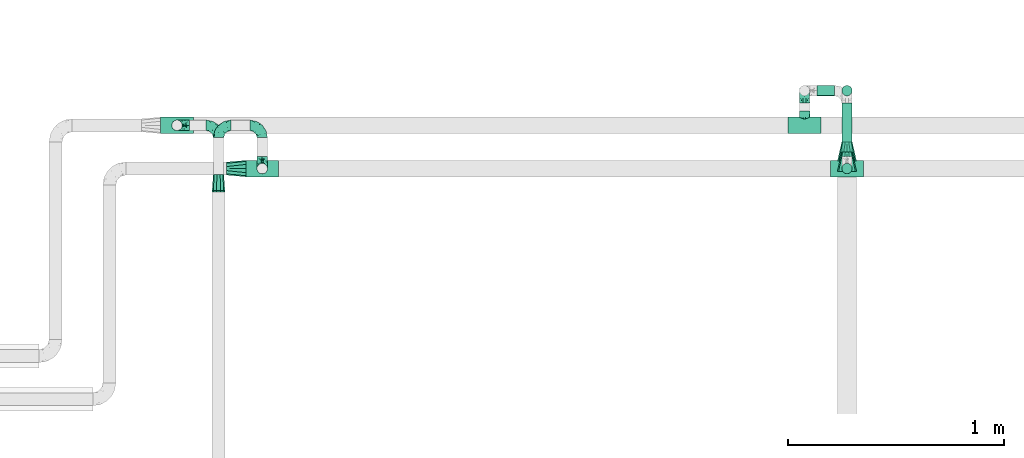
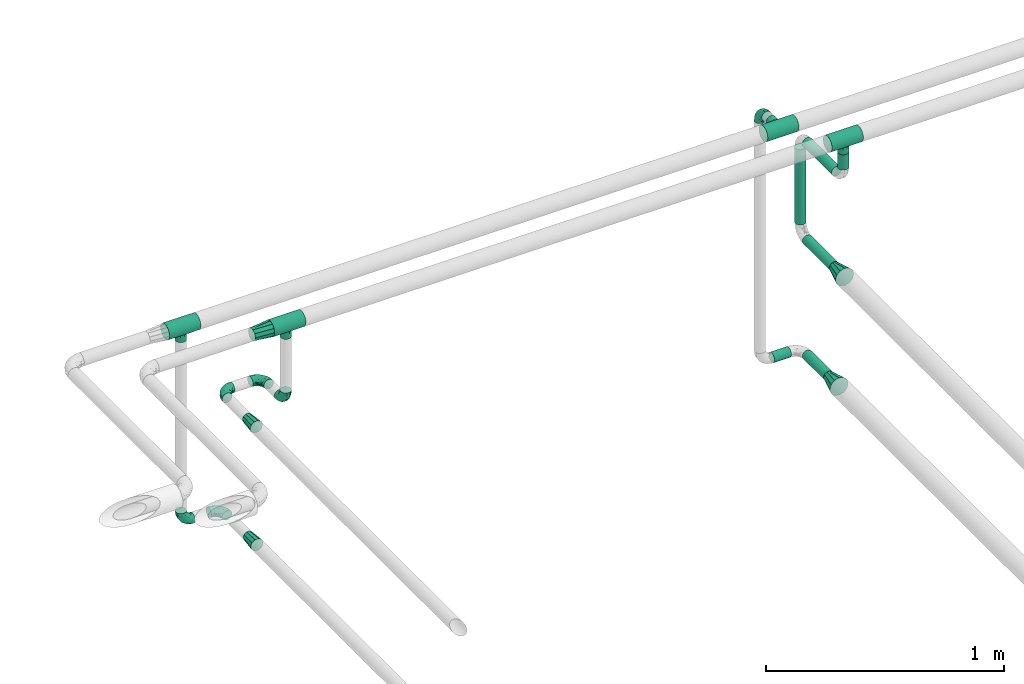
# One storey, part 592 of 824: 15 flow fittings, 6 flow segments.
"""IFC2X3 building model written with IfcOpenShell, lengths in millimetres."""

import ifcopenshell
import ifcopenshell.guid

model = None  # the IFC model being written
_history = None  # IfcOwnerHistory: only IFC2X3 demands one
_inside = {}  # id of a spatial element -> (the spatial element, [elements in it])
_under = {}  # id of a project, library or spatial element -> (it, [spatial elements below it])
_declared = {}  # id of a project -> (the project, [libraries it declares])
_typed = {}  # id of a type object -> (the type object, [elements of that type])
_made_of = {}  # id of a material, layer set ... -> (it, [elements and type objects made of it])


def new_model(schema):
    """Start an empty IFC model of exactly this schema.

    Asked for "IFC4X3", IfcOpenShell would pick the latest addendum, in which some entities
    have other attributes; the version numbers below select the first issue.
    IFC2X3 requires an IfcOwnerHistory on every rooted entity: one is made here for all.
    """
    global model, _history
    if schema == "IFC4X3":
        model = ifcopenshell.file(schema_version=(4, 3, 0, 0))
    else:
        model = ifcopenshell.file(schema=schema)
    _inside.clear()
    _under.clear()
    _declared.clear()
    _typed.clear()
    _made_of.clear()
    _history = None
    if model.schema == "IFC2X3":
        org = make("IfcOrganization", Name="unknown")
        user = make(
            "IfcPersonAndOrganization",
            ThePerson=make("IfcPerson", FamilyName="unknown"),
            TheOrganization=org,
        )
        app = make(
            "IfcApplication",
            ApplicationDeveloper=org,
            Version="unknown",
            ApplicationFullName="unknown",
            ApplicationIdentifier="unknown",
        )
        _history = make(
            "IfcOwnerHistory",
            OwningUser=user,
            OwningApplication=app,
            ChangeAction="ADDED",
            CreationDate=0,
        )
    return model


def make(cls, **values):
    """One entity of the class cls with the attributes given. An attribute that is None is left unset."""
    return model.create_entity(
        cls, **{name: value for name, value in values.items() if value is not None}
    )


def entity(cls, *values):
    """Any entity or typed value of the class cls, its attributes in the order of the schema. None: left unset."""
    e = model.create_entity(cls)
    for i, value in enumerate(values):
        if value is not None:
            e[i] = value
    return e


def rooted(cls, **values):
    """An entity with a GlobalId (a new one), such as an element, a storey or a relation."""
    return make(cls, GlobalId=ifcopenshell.guid.new(), OwnerHistory=_history, **values)


def si_unit(unit_type, name, prefix=None):
    """IfcSIUnit, for example si_unit("LENGTHUNIT", "METRE", prefix="MILLI")."""
    return make("IfcSIUnit", UnitType=unit_type, Prefix=prefix, Name=name)


def converted_unit(unit_type, name, factor, base, dimensions=None, offset=None):
    """IfcConversionBasedUnit, such as the inch: factor (a typed value) times the base unit."""
    return make(
        "IfcConversionBasedUnit"
        if offset is None
        else "IfcConversionBasedUnitWithOffset",
        ConversionOffset=offset,
        Dimensions=None
        if dimensions is None
        else entity("IfcDimensionalExponents", *dimensions),
        UnitType=unit_type,
        Name=name,
        ConversionFactor=make(
            "IfcMeasureWithUnit", ValueComponent=factor, UnitComponent=base
        ),
    )


def derived_unit(unit_type, elements):
    """IfcDerivedUnit: a product of units, each with its exponent."""
    return make(
        "IfcDerivedUnit",
        Elements=[
            make("IfcDerivedUnitElement", Unit=unit, Exponent=power)
            for unit, power in elements
        ],
        UnitType=unit_type,
    )


def assignment(units):
    """IfcUnitAssignment: the units of a project."""
    return None if units is None else make("IfcUnitAssignment", Units=units)


def point(xyz):
    """IfcCartesianPoint."""
    return None if xyz is None else make("IfcCartesianPoint", Coordinates=xyz)


def direction(xyz):
    """IfcDirection."""
    return None if xyz is None else make("IfcDirection", DirectionRatios=xyz)


def frame(location, z_axis=None, x_axis=None):
    """IfcAxis2Placement3D, a coordinate frame: its origin and axes. An axis left out is left unset."""
    return make(
        "IfcAxis2Placement3D",
        Location=point(location),
        Axis=direction(z_axis),
        RefDirection=direction(x_axis),
    )


def frame_2d(location, x_axis=None):
    """IfcAxis2Placement2D, a coordinate frame in the plane: its origin and x axis."""
    return make(
        "IfcAxis2Placement2D", Location=point(location), RefDirection=direction(x_axis)
    )


def origin():
    """The frame at (0, 0, 0) with its axes left unset."""
    return frame((0.0, 0.0, 0.0))


def origin_2d_with_axis():
    """The frame at (0, 0) in the plane with the x axis (1, 0) written out."""
    return frame_2d((0.0, 0.0), x_axis=(1.0, 0.0))


def place(relative_to, where):
    """IfcLocalPlacement: puts the frame where relative to a parent placement (None: the world)."""
    return make(
        "IfcLocalPlacement", PlacementRelTo=relative_to, RelativePlacement=where
    )


def context(
    kind, dimensions, precision=None, world=None, true_north=None, identifier=None
):
    """IfcGeometricRepresentationContext, for example the 3D "Model" context."""
    return make(
        "IfcGeometricRepresentationContext",
        ContextIdentifier=identifier,
        ContextType=kind,
        CoordinateSpaceDimension=dimensions,
        Precision=precision,
        WorldCoordinateSystem=world,
        TrueNorth=true_north,
    )


def subcontext(parent, identifier, kind, view, scale=None):
    """IfcGeometricRepresentationSubContext, for example "Body" below "Model"."""
    return make(
        "IfcGeometricRepresentationSubContext",
        ContextIdentifier=identifier,
        ContextType=kind,
        ParentContext=parent,
        TargetScale=scale,
        TargetView=view,
    )


def project(units=None, contexts=None):
    """IfcProject with its units and contexts."""
    return rooted(
        "IfcProject",
        Name="project",
        RepresentationContexts=contexts,
        UnitsInContext=assignment(units),
    )


def spatial(cls, under=None, at=None, **own):
    """A site, building, storey or space (cls), placed at a placement, below another one or the project."""
    s = rooted(cls, ObjectPlacement=at, **own)
    if under is not None:
        _under.setdefault(under.id(), (under, []))[1].append(s)
    return s


def profile(cls, at=None, kind="AREA", **sizes):
    """A parametric profile (cls). Its sizes go by their IFC names, for example OverallWidth=200.0."""
    return make(cls, ProfileType=kind, Position=at, **sizes)


def circle(**sizes):
    """IfcCircleProfileDef."""
    return profile("IfcCircleProfileDef", **sizes)


def extrude(swept, where, along, depth):
    """IfcExtrudedAreaSolid: the profile swept, set in the frame where, extruded along a direction by depth."""
    return make(
        "IfcExtrudedAreaSolid",
        SweptArea=swept,
        Position=where,
        ExtrudedDirection=direction(along),
        Depth=depth,
    )


def faces_of(points, faces, orient=None, outer=None):
    """IfcFace entities. A face is a list of loops; a loop is a list of indices into points, from 0.

    orient and outer hold one flag for each loop. By default every Orientation is true, the
    first loop of a face is its IfcFaceOuterBound and the others are IfcFaceBound.
    """
    made = []
    for i, loops in enumerate(faces):
        bounds = []
        for j, loop in enumerate(loops):
            is_outer = j == 0 if outer is None else outer[i][j]
            bounds.append(
                make(
                    "IfcFaceOuterBound" if is_outer else "IfcFaceBound",
                    Bound=make("IfcPolyLoop", Polygon=[points[k] for k in loop]),
                    Orientation=True if orient is None else orient[i][j],
                )
            )
        made.append(make("IfcFace", Bounds=bounds))
    return made


def faceted_brep(points, faces, orient=None, outer=None, voids=None):
    """IfcFacetedBrep: a solid bounded by flat faces; with voids (closed shells), ...WithVoids."""
    shared = [point(p) for p in points]
    hull = make("IfcClosedShell", CfsFaces=faces_of(shared, faces, orient, outer))
    if voids is None:
        return make("IfcFacetedBrep", Outer=hull)
    return make(
        "IfcFacetedBrepWithVoids",
        Outer=hull,
        Voids=[
            make(cls, CfsFaces=faces_of(shared, fs, o, b)) for cls, fs, o, b in voids
        ],
    )


def shape(context_of_items, identifier, shape_type, items):
    """IfcShapeRepresentation: the items that make up one representation, for example the "Body"."""
    return make(
        "IfcShapeRepresentation",
        ContextOfItems=context_of_items,
        RepresentationIdentifier=identifier,
        RepresentationType=shape_type,
        Items=items,
    )


def source(mapping_origin, context_of_items, identifier, shape_type, items):
    """IfcRepresentationMap: a shape defined once, which mapped items show again and again."""
    return make(
        "IfcRepresentationMap",
        MappingOrigin=mapping_origin,
        MappedRepresentation=shape(context_of_items, identifier, shape_type, items),
    )


def transform(
    local_origin,
    x_axis=None,
    y_axis=None,
    z_axis=None,
    scale=None,
    scale2=None,
    scale3=None,
    uniform=True,
):
    """IfcCartesianTransformationOperator3D, or its non-uniform kind. x_axis, y_axis, z_axis: its Axis1, 2, 3."""
    if uniform:
        return make(
            "IfcCartesianTransformationOperator3D",
            Axis1=direction(x_axis),
            Axis2=direction(y_axis),
            LocalOrigin=point(local_origin),
            Scale=scale,
            Axis3=direction(z_axis),
        )
    return make(
        "IfcCartesianTransformationOperator3DnonUniform",
        Axis1=direction(x_axis),
        Axis2=direction(y_axis),
        LocalOrigin=point(local_origin),
        Scale=scale,
        Axis3=direction(z_axis),
        Scale2=scale2,
        Scale3=scale3,
    )


def mapped(mapping_source, mapping_target):
    """IfcMappedItem: shows the shape of a source again, moved by a transform."""
    return make(
        "IfcMappedItem", MappingSource=mapping_source, MappingTarget=mapping_target
    )


def material(Name=None, Category=None):
    """IfcMaterial."""
    return make("IfcMaterial", Name=Name, Category=Category)


def made_of(thing, what):
    """Note that an element or type object is made of a material, layer set ...; save() writes the relation."""
    if what is not None:
        _made_of.setdefault(what.id(), (what, []))[1].append(thing)
    return thing


def type_object(cls, material=None, **own):
    """A type object (cls), such as IfcWallType, which elements share."""
    return made_of(rooted(cls, **own), material)


def type_shapes(of_type, sources):
    """Give a type object the sources (RepresentationMaps) that its elements show as mapped items."""
    of_type.RepresentationMaps = sources


def element(
    cls,
    number,
    at=None,
    inside=None,
    cuts=None,
    type_object=None,
    material=None,
    context=None,
    identifier="Body",
    shape_type=None,
    held_by="IfcProductDefinitionShape",
    body=None,
    shapes=None,
    **own,
):
    """One element of the class cls, such as IfcWall. Its Tag is "e" and its number.

    at: its placement. inside: the storey or other place that contains it. cuts: it is an
    opening in that element (IfcRelVoidsElement). A single representation is given by context,
    identifier, shape_type and body (its items); several are given by shapes. held_by: the class
    of the entity that holds the representations. save() writes the other relations.
    """
    e = rooted(cls, Tag="e%d" % number, ObjectPlacement=at, **own)
    if body is not None:
        shapes = [shape(context, identifier, shape_type, body)]
    if shapes is not None:
        e.Representation = make(held_by, Representations=shapes)
    if inside is not None:
        _inside.setdefault(inside.id(), (inside, []))[1].append(e)
    if cuts is not None:
        rooted(
            "IfcRelVoidsElement", RelatingBuildingElement=cuts, RelatedOpeningElement=e
        )
    if type_object is not None:
        _typed.setdefault(type_object.id(), (type_object, []))[1].append(e)
    return made_of(e, material)


def aggregate(whole, parts):
    """IfcRelAggregates: a whole, such as a stair, and the parts it consists of."""
    return rooted("IfcRelAggregates", RelatingObject=whole, RelatedObjects=parts)


def save(model, path):
    """Write the relations noted so far, then the file.

    IfcRelAggregates (storeys below a building ...), IfcRelContainedInSpatialStructure (elements
    in a storey), IfcRelDefinesByType, IfcRelAssociatesMaterial and IfcRelDeclares: one each for
    every whole, place, type object, material and project.
    """
    for whole, parts in _under.values():
        aggregate(whole, parts)
    for where, things in _inside.values():
        rooted(
            "IfcRelContainedInSpatialStructure",
            RelatedElements=things,
            RelatingStructure=where,
        )
    for kind, things in _typed.values():
        rooted("IfcRelDefinesByType", RelatedObjects=things, RelatingType=kind)
    for what, things in _made_of.values():
        rooted("IfcRelAssociatesMaterial", RelatedObjects=things, RelatingMaterial=what)
    for by, libraries in _declared.values():
        rooted("IfcRelDeclares", RelatingContext=by, RelatedDefinitions=libraries)
    model.write(path)


model = new_model("IFC2X3")

# Units and contexts
model_context = context("Model", 3, precision=0.01, world=origin(), true_north=direction((6.12303176911189e-17, 1.0)))
body_context = subcontext(model_context, "Body", "Model", "MODEL_VIEW")
ifc_project = project(units=[si_unit("LENGTHUNIT", "METRE", prefix="MILLI"), si_unit("AREAUNIT", "SQUARE_METRE"), si_unit("VOLUMEUNIT", "CUBIC_METRE"), converted_unit("PLANEANGLEUNIT", "DEGREE", entity("IfcRatioMeasure", 0.0174532925199433), si_unit("PLANEANGLEUNIT", "RADIAN"), dimensions=[0, 0, 0, 0, 0, 0, 0]), si_unit("MASSUNIT", "GRAM", prefix="KILO"), derived_unit("MASSDENSITYUNIT", [(si_unit("MASSUNIT", "GRAM", prefix="KILO"), 1), (si_unit("LENGTHUNIT", "METRE"), -3)]), derived_unit("MOMENTOFINERTIAUNIT", [(si_unit("LENGTHUNIT", "METRE"), 4)]), si_unit("TIMEUNIT", "SECOND"), si_unit("FREQUENCYUNIT", "HERTZ"), si_unit("THERMODYNAMICTEMPERATUREUNIT", "DEGREE_CELSIUS"), derived_unit("THERMALTRANSMITTANCEUNIT", [(si_unit("MASSUNIT", "GRAM", prefix="KILO"), 1), (si_unit("THERMODYNAMICTEMPERATUREUNIT", "KELVIN"), -1), (si_unit("TIMEUNIT", "SECOND"), -3)]), derived_unit("VOLUMETRICFLOWRATEUNIT", [(si_unit("LENGTHUNIT", "METRE"), 3), (si_unit("TIMEUNIT", "SECOND"), -1)]), derived_unit("MASSFLOWRATEUNIT", [(si_unit("MASSUNIT", "GRAM", prefix="KILO"), 1), (si_unit("TIMEUNIT", "SECOND"), -1)]), derived_unit("ROTATIONALFREQUENCYUNIT", [(si_unit("TIMEUNIT", "SECOND"), -1)]), si_unit("ELECTRICCURRENTUNIT", "AMPERE"), si_unit("ELECTRICVOLTAGEUNIT", "VOLT"), si_unit("POWERUNIT", "WATT"), si_unit("FORCEUNIT", "NEWTON", prefix="KILO"), si_unit("ILLUMINANCEUNIT", "LUX"), si_unit("LUMINOUSFLUXUNIT", "LUMEN"), si_unit("LUMINOUSINTENSITYUNIT", "CANDELA"), derived_unit("USERDEFINED", [(si_unit("MASSUNIT", "GRAM", prefix="KILO"), -1), (si_unit("LENGTHUNIT", "METRE"), -2), (si_unit("TIMEUNIT", "SECOND"), 3), (si_unit("LUMINOUSFLUXUNIT", "LUMEN"), 1)]), derived_unit("LINEARVELOCITYUNIT", [(si_unit("LENGTHUNIT", "METRE"), 1), (si_unit("TIMEUNIT", "SECOND"), -1)]), si_unit("PRESSUREUNIT", "PASCAL"), derived_unit("USERDEFINED", [(si_unit("LENGTHUNIT", "METRE"), -2), (si_unit("MASSUNIT", "GRAM", prefix="KILO"), 1), (si_unit("TIMEUNIT", "SECOND"), -2)]), derived_unit("LINEARFORCEUNIT", [(si_unit("MASSUNIT", "GRAM", prefix="KILO"), 1), (si_unit("LENGTHUNIT", "METRE"), 1), (si_unit("TIMEUNIT", "SECOND"), -2), (si_unit("LENGTHUNIT", "METRE"), -1)]), derived_unit("PLANARFORCEUNIT", [(si_unit("MASSUNIT", "GRAM", prefix="KILO"), 1), (si_unit("LENGTHUNIT", "METRE"), 1), (si_unit("TIMEUNIT", "SECOND"), -2), (si_unit("LENGTHUNIT", "METRE"), -2)])], contexts=[model_context])

# Site, building, storey
site_placement = place(None, origin())
site = spatial("IfcSite", under=ifc_project, at=site_placement, CompositionType="ELEMENT")
building_placement = place(site_placement, origin())
building = spatial("IfcBuilding", under=site, at=building_placement, CompositionType="ELEMENT")
storey_placement = place(building_placement, frame((0.0, 0.0, 28200.0)))
storey = spatial("IfcBuildingStorey", under=building, at=storey_placement, CompositionType="ELEMENT", Elevation=28200.0)

# Flow segments
pipe_segment_type = type_object("IfcPipeSegmentType", PredefinedType="NOTDEFINED")
flow_segment_1_placement = place(storey_placement, frame((22797.03, 19214.7, 1681.46)))
element("IfcFlowSegment", 1, at=flow_segment_1_placement, inside=storey, type_object=pipe_segment_type, context=body_context, shape_type="SweptSolid", body=[
    extrude(circle(Radius=24.0, at=origin_2d_with_axis()), frame((0.0, 25.6, 25.6), z_axis=(1.0, 0.0, 0.0), x_axis=(0.0, -1.0, 0.0)), (0.0, 0.0, 1.0), 82.4311413009261),
])
flow_segment_2_placement = place(storey_placement, frame((22910.87, 18956.47, 2271.67)))
element("IfcFlowSegment", 2, at=flow_segment_2_placement, inside=storey, type_object=pipe_segment_type, context=body_context, shape_type="SweptSolid", body=[
    extrude(circle(Radius=24.0, at=origin_2d_with_axis()), frame((25.6, 0.0, 25.6), z_axis=(0.0, 1.0, 0.0), x_axis=(-1.0, 0.0, 0.0)), (0.0, 0.0, 1.0), 226.824749183208),
])
flow_segment_3_placement = place(storey_placement, frame((22910.87, 19003.8, 1681.46)))
element("IfcFlowSegment", 3, at=flow_segment_3_placement, inside=storey, type_object=pipe_segment_type, context=body_context, shape_type="SweptSolid", body=[
    extrude(circle(Radius=24.0, at=origin_2d_with_axis()), frame((25.6, 0.0, 25.6), z_axis=(0.0, 1.0, 0.0), x_axis=(-1.0, 0.0, 0.0)), (0.0, 0.0, 1.0), 179.5),
])
flow_segment_4_placement = place(storey_placement, frame((22910.87, 19214.7, 2354.26)))
element("IfcFlowSegment", 4, at=flow_segment_4_placement, inside=storey, type_object=pipe_segment_type, context=body_context, shape_type="SweptSolid", body=[
    extrude(circle(Radius=24.0, at=origin_2d_with_axis()), frame((25.6, 25.6, 0.0), z_axis=(0.0, 0.0, 1.0), x_axis=(-1.0, 0.0, 0.0)), (0.0, 0.0, 1.0), 386.000000000016),
])
flow_segment_5_placement = place(storey_placement, frame((22910.87, 18937.0, 2771.67)))
element("IfcFlowSegment", 5, at=flow_segment_5_placement, inside=storey, type_object=pipe_segment_type, context=body_context, shape_type="SweptSolid", body=[
    extrude(circle(Radius=24.0, at=origin_2d_with_axis()), frame((25.6, 0.0, 25.6), z_axis=(0.0, 1.0, 0.0), x_axis=(1.0, 0.0, 0.0)), (0.0, 0.0, 1.0), 246.299912871601),
])
flow_segment_6_placement = place(storey_placement, frame((22910.87, 18854.4, 2854.26)))
element("IfcFlowSegment", 6, at=flow_segment_6_placement, inside=storey, type_object=pipe_segment_type, context=body_context, shape_type="SweptSolid", body=[
    extrude(circle(Radius=24.0, at=origin_2d_with_axis()), frame((25.6, 25.6, 0.0), z_axis=(0.0, 0.0, 1.0), x_axis=(-1.0, 0.0, 0.0)), (0.0, 0.0, 1.0), 78.7384679313723),
])

# Flow fittings
ifc_material = material()
pipe_fitting_type_1 = type_object("IfcPipeFittingType", PredefinedType="NOTDEFINED", material=ifc_material)
shared_shape_1 = source(origin(), body_context, "Body", "Brep", [
    faceted_brep([(-76.0, 9.85, -36.75), (-76.0, 0.0, -38.05), (-76.0, -9.85, -36.75), (-76.0, -19.03, -32.95), (-76.0, -26.91, -26.91), (-76.0, -32.95, -19.03), (-76.0, -36.75, -9.85), (-76.0, -38.05, 0.0), (-76.0, -36.75, 9.85), (-76.0, -32.95, 19.02), (-76.0, -26.91, 26.91), (-76.0, -19.03, 32.95), (-76.0, -9.85, 36.75), (-76.0, 0.0, 38.05), (-76.0, 9.85, 36.75), (-76.0, 19.02, 32.95), (-76.0, 26.91, 26.91), (-76.0, 32.95, 19.02), (-76.0, 36.75, 9.85), (-76.0, 38.05, 0.0), (-76.0, 36.75, -9.85), (-76.0, 32.95, -19.03), (-76.0, 26.91, -26.91), (-76.0, 19.02, -32.95), (76.0, 26.91, -26.91), (76.0, 32.95, -19.03), (76.0, 36.75, -9.85), (76.0, 38.05, 0.0), (76.0, 36.75, 9.85), (76.0, 32.95, 19.02), (76.0, 26.91, 26.91), (76.0, 19.02, 32.95), (76.0, 9.85, 36.75), (76.0, 0.0, 38.05), (76.0, -9.85, 36.75), (76.0, -19.03, 32.95), (76.0, -26.91, 26.91), (76.0, -32.95, 19.02), (76.0, -36.75, 9.85), (76.0, -38.05, 0.0), (76.0, -36.75, -9.85), (76.0, -32.95, -19.03), (76.0, -26.91, -26.91), (76.0, -19.03, -32.95), (76.0, -9.85, -36.75), (76.0, 0.0, -38.05), (76.0, 9.85, -36.75), (76.0, 19.02, -32.95), (22.62, -37.1, 8.45), (23.39, -37.58, 4.22), (24.15, -38.05, 0.0), (18.42, -34.7, 15.61), (4.31, -29.72, 23.76), (12.18, -31.83, 20.86), (8.24, -30.77, 22.31), (-24.15, -38.05, 0.0), (-23.39, -37.58, 4.22), (-22.63, -37.1, 8.44), (-18.43, -34.7, 15.61), (-12.18, -31.83, 20.85), (-4.31, -29.72, 23.76), (0.0, -29.72, 23.76), (4.31, -29.72, -23.76), (12.18, -31.83, -20.86), (8.24, -30.77, -22.31), (18.42, -34.7, -15.61), (22.62, -37.1, -8.45), (23.39, -37.58, -4.22), (-4.31, -29.72, -23.76), (-12.18, -31.83, -20.85), (-18.43, -34.7, -15.61), (0.0, -29.72, -23.76), (-22.63, -37.1, -8.44), (-23.39, -37.58, -4.22), (0.0, -67.0, -24.15), (6.25, -67.0, -23.33), (12.08, -67.0, -20.91), (17.08, -67.0, -17.08), (20.91, -67.0, -12.08), (23.33, -67.0, -6.25), (24.15, -67.0, 0.0), (23.33, -67.0, 6.25), (20.91, -67.0, 12.07), (17.08, -67.0, 17.08), (12.08, -67.0, 20.91), (6.25, -67.0, 23.33), (0.0, -67.0, 24.15), (-6.25, -67.0, 23.33), (-12.07, -67.0, 20.91), (-17.08, -67.0, 17.08), (-20.91, -67.0, 12.07), (-23.33, -67.0, 6.25), (-24.15, -67.0, 0.0), (-23.33, -67.0, -6.25), (-20.91, -67.0, -12.08), (-17.08, -67.0, -17.08), (-12.07, -67.0, -20.91), (-6.25, -67.0, -23.33)], [[[0, 1, 2, 3, 4, 5, 6, 7, 8, 9, 10, 11, 12, 13, 14, 15, 16, 17, 18, 19, 20, 21, 22, 23]], [[24, 25, 26, 27, 28, 29, 30, 31, 32, 33, 34, 35, 36, 37, 38, 39, 40, 41, 42, 43, 44, 45, 46, 47]], [[39, 38, 48]], [[39, 48, 49, 50]], [[38, 51, 48]], [[37, 36, 52]], [[53, 51, 37]], [[37, 52, 54, 53]], [[36, 10, 52]], [[37, 51, 38]], [[7, 55, 56, 57]], [[8, 7, 57]], [[57, 58, 8]], [[59, 60, 9]], [[59, 9, 58]], [[9, 60, 10]], [[58, 9, 8]], [[10, 60, 61, 52]], [[36, 35, 11, 10]], [[13, 12, 34, 33]], [[12, 11, 35, 34]], [[14, 13, 33, 32]], [[29, 28, 18, 17]], [[16, 15, 31, 30]], [[17, 16, 30, 29]], [[32, 31, 15, 14]], [[19, 18, 28, 27]], [[26, 25, 21, 20]], [[25, 24, 22, 21]], [[27, 26, 20, 19]], [[45, 44, 2, 1]], [[0, 23, 47, 46]], [[1, 0, 46, 45]], [[24, 47, 23, 22]], [[3, 2, 44, 43]], [[43, 42, 4, 3]], [[42, 41, 62]], [[41, 63, 64, 62]], [[41, 65, 63]], [[42, 62, 4]], [[40, 39, 66]], [[66, 65, 40]], [[39, 50, 67, 66]], [[40, 65, 41]], [[68, 69, 5]], [[5, 4, 68]], [[69, 70, 5]], [[4, 62, 71, 68]], [[70, 72, 6]], [[72, 7, 6]], [[7, 72, 73, 55]], [[70, 6, 5]], [[74, 75, 76, 77, 78, 79, 80, 81, 82, 83, 84, 85, 86, 87, 88, 89, 90, 91, 92, 93, 94, 95, 96, 97]], [[56, 92, 91]], [[86, 60, 87]], [[59, 89, 88]], [[84, 54, 85]], [[49, 80, 50]], [[59, 88, 87]], [[49, 48, 81]], [[91, 57, 56]], [[55, 92, 56]], [[57, 91, 90]], [[57, 90, 58]], [[89, 58, 90]], [[89, 59, 58]], [[87, 60, 59]], [[86, 52, 61, 60]], [[84, 53, 54]], [[83, 53, 84]], [[48, 82, 81]], [[83, 82, 51]], [[52, 86, 85]], [[54, 52, 85]], [[53, 83, 51]], [[51, 82, 48]], [[80, 49, 81]], [[79, 67, 80]], [[77, 65, 78]], [[64, 76, 75]], [[79, 66, 67]], [[78, 66, 79]], [[63, 77, 76]], [[67, 50, 80]], [[66, 78, 65]], [[75, 62, 64]], [[63, 65, 77]], [[74, 68, 71, 62]], [[74, 62, 75]], [[73, 92, 55]], [[69, 97, 96]], [[73, 72, 93]], [[95, 69, 96]], [[72, 94, 93]], [[95, 94, 70]], [[68, 74, 97]], [[97, 69, 68]], [[69, 95, 70]], [[70, 94, 72]], [[92, 73, 93]], [[64, 63, 76]]]),
])
type_shapes(pipe_fitting_type_1, [shared_shape_1])
for number, where, z_axis, x_axis in (
    (7, (20231.46, 18880.0, 3000.0), (0.0, 1.0, 0.0), (-1.0, 0.0, 0.0)),
    (8, (19837.21, 19080.0, 3000.0), (0.0, 1.0, 0.0), (-1.0, 0.0, 0.0)),
    (9, (22936.46, 18880.0, 3000.0), (0.0, 1.0, 0.0), (-1.0, 0.0, 0.0)),
    (10, (22740.03, 19080.0, 3000.0), (0.0, 0.0, 1.0), (-1.0, 0.0, 0.0)),
):
    element("IfcFlowFitting", number, at=place(storey_placement, frame(where, z_axis=z_axis, x_axis=x_axis)), inside=storey, type_object=pipe_fitting_type_1, material=ifc_material, context=body_context, shape_type="MappedRepresentation", body=[
        mapped(shared_shape_1, transform((0.0, 0.0, 0.0), scale=1.0)),
    ])
pipe_fitting_type_2 = type_object("IfcPipeFittingType", PredefinedType="NOTDEFINED", material=ifc_material)
shared_shape_2 = source(origin(), body_context, "Body", "Brep", [
    faceted_brep([(-57.0, 12.07, -20.91), (-57.0, 6.25, -23.33), (-57.0, 0.0, -24.15), (-57.0, -6.25, -23.33), (-57.0, -12.08, -20.91), (-57.0, -17.08, -17.08), (-57.0, -20.91, -12.08), (-57.0, -23.33, -6.25), (-57.0, -24.15, 0.0), (-57.0, -23.33, 6.25), (-57.0, -20.91, 12.07), (-57.0, -17.08, 17.08), (-57.0, -12.08, 20.91), (-57.0, -6.25, 23.33), (-57.0, 0.0, 24.15), (-57.0, 6.25, 23.33), (-57.0, 12.07, 20.91), (-57.0, 17.08, 17.08), (-57.0, 20.91, 12.07), (-57.0, 23.33, 6.25), (-57.0, 24.15, 0.0), (-57.0, 23.33, -6.25), (-57.0, 20.91, -12.08), (-57.0, 17.08, -17.08), (0.0, 57.0, -24.15), (-6.25, 57.0, -23.33), (-12.07, 57.0, -20.91), (-17.08, 57.0, -17.08), (-20.91, 57.0, -12.08), (-23.33, 57.0, -6.25), (-24.15, 57.0, 0.0), (-23.33, 57.0, 6.25), (-20.91, 57.0, 12.07), (-17.08, 57.0, 17.08), (-12.07, 57.0, 20.91), (-6.25, 57.0, 23.33), (0.0, 57.0, 24.15), (6.25, 57.0, 23.33), (12.08, 57.0, 20.91), (17.08, 57.0, 17.08), (20.91, 57.0, 12.07), (23.33, 57.0, 6.25), (24.15, 57.0, 0.0), (23.33, 57.0, -6.25), (20.91, 57.0, -12.08), (17.08, 57.0, -17.08), (12.08, 57.0, -20.91), (6.25, 57.0, -23.33), (14.9, 21.14, 6.17), (13.61, 24.64, 12.48), (6.23, 8.95, 8.98), (-41.47, -21.06, 0.0), (-41.92, -18.38, 13.72), (-24.64, -13.61, 12.48), (-37.37, -13.24, 18.15), (-6.8, -4.93, 8.18), (-21.76, -15.19, 6.22), (-12.78, -9.18, 0.0), (-37.73, -20.51, 7.75), (-7.38, 7.38, 20.24), (-23.37, -4.26, 20.42), (-11.9, -3.19, 15.86), (-42.14, -8.7, 21.82), (13.24, 37.37, 18.15), (9.33, 23.53, 16.85), (4.26, 23.37, 20.42), (2.77, 10.92, 15.55), (-29.46, 0.91, 23.52), (-44.13, 20.56, 15.69), (-39.25, 26.33, 10.88), (-49.02, 22.92, 9.96), (-34.58, 23.87, 17.15), (-15.8, 6.8, 22.81), (-8.67, 20.47, 23.88), (-18.12, 12.9, 24.08), (-48.29, 14.92, 19.65), (-44.06, -2.85, 23.78), (-9.23, 48.95, 22.58), (-3.78, 42.74, 24.07), (-40.34, 4.26, 24.09), (-44.02, 26.14, 5.46), (-44.04, 9.88, 22.74), (-4.95, 16.87, 22.52), (-2.75, 1.43, 12.5), (-25.48, 40.98, 10.71), (20.51, 37.73, 7.75), (18.38, 41.92, 13.72), (8.7, 42.14, 21.82), (-25.95, -17.97, 0.0), (2.85, 44.06, 23.78), (21.06, 41.47, 0.0), (17.97, 25.95, 0.0), (-24.04, -9.27, 17.13), (-33.26, 33.26, 5.86), (-28.55, 40.57, 0.0), (-40.57, 28.55, 0.0), (-25.29, 47.19, 4.06), (-27.01, 31.1, 16.77), (-15.7, 43.95, 19.9), (-20.27, 45.22, 15.61), (-30.53, 31.98, 12.64), (-11.28, 38.33, 22.92), (-9.97, 27.88, 24.09), (-20.15, 30.26, 21.25), (-31.25, 11.75, 23.64), (-28.75, 7.23, 24.15), (-29.53, 18.06, 22.27), (-28.44, 24.21, 20.02), (-37.55, 17.7, 20.26), (-15.88, 29.25, 22.99), (-20.82, 20.82, 23.44), (-0.91, 29.46, 23.52), (-13.5, -7.67, 12.04), (1.49, 1.56, 5.16), (8.86, 10.35, 4.59), (0.38, -0.38, 0.0), (9.18, 12.78, 0.0), (-37.37, -13.24, -18.15), (8.86, 10.35, -4.59), (-45.22, 20.27, -15.61), (-43.95, 15.7, -19.9), (-38.33, 11.28, -22.92), (-48.95, 9.23, -22.58), (-47.19, 25.29, -4.06), (-33.26, 33.26, -5.86), (18.38, 41.92, -13.72), (-30.26, 20.15, -21.25), (2.85, 44.06, -23.78), (-4.26, 40.34, -24.09), (-40.98, 25.48, -10.71), (-41.92, -18.38, -13.72), (9.25, 23.5, -16.92), (4.26, 23.37, -20.42), (13.24, 37.37, -18.15), (-37.73, -20.51, -7.75), (-11.75, 31.25, -23.64), (-7.23, 28.75, -24.15), (-12.9, 18.12, -24.08), (8.7, 42.14, -21.82), (-44.06, -2.85, -23.78), (-6.8, 15.8, -22.81), (-20.47, 8.67, -23.88), (-24.64, -13.61, -12.48), (-42.74, 3.78, -24.07), (-18.06, 29.53, -22.27), (-24.21, 28.44, -20.02), (-27.88, 9.97, -24.09), (-31.1, 27.01, -16.77), (-26.14, 44.02, -5.46), (14.9, 21.14, -6.17), (20.51, 37.73, -7.75), (-9.88, 44.04, -22.74), (-20.56, 44.13, -15.69), (-21.76, -15.19, -6.22), (-13.5, -7.67, -12.04), (-24.14, -9.76, -16.74), (-11.9, -3.19, -15.86), (-14.92, 48.29, -19.65), (-23.37, -4.26, -20.42), (-0.91, 29.46, -23.52), (-26.33, 39.25, -10.88), (-23.87, 34.58, -17.15), (-42.14, -8.7, -21.82), (-22.92, 49.02, -9.96), (13.61, 24.64, -12.48), (-31.98, 30.53, -12.64), (-16.87, 4.95, -22.52), (-17.7, 37.55, -20.26), (-29.25, 15.88, -22.99), (-20.82, 20.82, -23.44), (-29.46, 0.91, -23.52), (-7.38, 7.38, -20.24), (2.77, 10.92, -15.55), (6.23, 8.95, -8.98), (-6.8, -4.93, -8.18), (-2.81, 1.41, -12.54), (1.49, 1.56, -5.16)], [[[0, 1, 2, 3, 4, 5, 6, 7, 8, 9, 10, 11, 12, 13, 14, 15, 16, 17, 18, 19, 20, 21, 22, 23]], [[24, 25, 26, 27, 28, 29, 30, 31, 32, 33, 34, 35, 36, 37, 38, 39, 40, 41, 42, 43, 44, 45, 46, 47]], [[48, 49, 50]], [[9, 8, 51]], [[52, 53, 54]], [[55, 56, 57]], [[10, 58, 52]], [[9, 58, 10]], [[59, 60, 61]], [[54, 12, 11]], [[54, 62, 12]], [[63, 39, 38]], [[64, 65, 66]], [[62, 60, 67]], [[68, 69, 70]], [[71, 69, 68]], [[72, 73, 74]], [[16, 75, 17]], [[13, 76, 14]], [[35, 77, 78]], [[14, 79, 15]], [[17, 68, 18]], [[14, 76, 79]], [[20, 19, 80]], [[70, 19, 18]], [[81, 15, 79]], [[15, 81, 16]], [[73, 72, 82]], [[66, 83, 50]], [[32, 31, 84]], [[85, 86, 49]], [[63, 87, 65]], [[56, 58, 88]], [[36, 89, 37]], [[85, 41, 40]], [[36, 35, 78]], [[90, 41, 85]], [[40, 39, 86]], [[12, 62, 13]], [[86, 85, 40]], [[48, 85, 49]], [[85, 91, 90]], [[87, 38, 37]], [[92, 60, 54]], [[80, 69, 93]], [[93, 94, 95]], [[10, 52, 11]], [[94, 96, 30]], [[97, 98, 99]], [[80, 93, 95]], [[100, 97, 84]], [[99, 98, 33]], [[101, 102, 78]], [[103, 101, 98]], [[96, 31, 30]], [[77, 98, 101]], [[77, 35, 34]], [[34, 33, 98]], [[9, 51, 58]], [[87, 63, 38]], [[104, 105, 74]], [[106, 103, 107]], [[106, 81, 104]], [[75, 68, 17]], [[108, 107, 71]], [[33, 32, 99]], [[109, 103, 110]], [[101, 109, 102]], [[89, 78, 111]], [[53, 52, 58]], [[54, 11, 52]], [[60, 62, 54]], [[88, 58, 51]], [[76, 62, 67]], [[53, 112, 92]], [[60, 59, 72]], [[39, 63, 86]], [[49, 86, 63]], [[89, 87, 37]], [[42, 41, 90]], [[111, 82, 65]], [[111, 65, 87]], [[65, 59, 66]], [[104, 81, 79]], [[75, 81, 108]], [[32, 84, 99]], [[97, 99, 84]], [[98, 97, 103]], [[106, 107, 108]], [[74, 102, 110]], [[111, 78, 102]], [[74, 110, 104]], [[74, 67, 72]], [[61, 92, 112]], [[66, 59, 61]], [[56, 53, 58]], [[66, 50, 49]], [[61, 112, 83]], [[66, 49, 64]], [[78, 89, 36]], [[87, 89, 111]], [[62, 76, 13]], [[79, 76, 67]], [[100, 93, 69]], [[96, 93, 84]], [[55, 113, 50]], [[113, 114, 50]], [[104, 79, 105]], [[106, 104, 110]], [[20, 80, 95]], [[85, 48, 91]], [[115, 114, 113]], [[116, 91, 48]], [[70, 80, 19]], [[93, 96, 94]], [[84, 31, 96]], [[103, 106, 110]], [[81, 106, 108]], [[103, 97, 107]], [[71, 107, 97]], [[71, 97, 100]], [[108, 71, 68]], [[79, 67, 105]], [[67, 74, 105]], [[115, 113, 57]], [[112, 56, 55]], [[56, 88, 57]], [[60, 72, 67]], [[82, 72, 59]], [[65, 82, 59]], [[82, 111, 73]], [[111, 102, 73]], [[102, 74, 73]], [[81, 75, 16]], [[68, 75, 108]], [[68, 70, 18]], [[80, 70, 69]], [[98, 77, 34]], [[78, 77, 101]], [[93, 100, 84]], [[71, 100, 69]], [[102, 109, 110]], [[101, 103, 109]], [[53, 92, 54]], [[61, 60, 92]], [[56, 112, 53]], [[83, 112, 55]], [[50, 83, 55]], [[61, 83, 66]], [[49, 63, 64]], [[65, 64, 63]], [[57, 113, 55]], [[114, 115, 116]], [[116, 48, 114]], [[48, 50, 114]], [[117, 5, 4]], [[116, 115, 118]], [[119, 120, 23]], [[121, 122, 120]], [[95, 123, 20]], [[0, 23, 120]], [[124, 95, 94]], [[125, 45, 44]], [[121, 120, 126]], [[24, 127, 128]], [[22, 21, 129]], [[0, 122, 1]], [[5, 117, 130]], [[131, 132, 133]], [[134, 88, 51]], [[135, 136, 137]], [[6, 5, 130]], [[46, 138, 47]], [[139, 3, 2]], [[140, 141, 137]], [[6, 134, 7]], [[134, 130, 142]], [[143, 2, 1]], [[144, 126, 145]], [[121, 146, 143]], [[147, 120, 119]], [[94, 148, 124]], [[149, 150, 91]], [[30, 29, 148]], [[151, 25, 128]], [[27, 152, 28]], [[134, 153, 88]], [[154, 155, 156]], [[27, 26, 157]], [[151, 26, 25]], [[155, 158, 156]], [[24, 47, 127]], [[1, 122, 143]], [[138, 132, 159]], [[160, 152, 161]], [[24, 128, 25]], [[46, 133, 138]], [[162, 117, 4]], [[148, 160, 124]], [[152, 160, 163]], [[154, 142, 155]], [[45, 125, 133]], [[133, 46, 45]], [[125, 164, 133]], [[51, 7, 134]], [[42, 90, 43]], [[165, 147, 129]], [[153, 134, 142]], [[43, 150, 44]], [[162, 4, 3]], [[141, 140, 166]], [[117, 162, 158]], [[163, 29, 28]], [[43, 90, 150]], [[123, 21, 20]], [[144, 151, 135]], [[157, 152, 27]], [[167, 145, 161]], [[23, 22, 119]], [[168, 126, 169]], [[121, 168, 146]], [[139, 143, 170]], [[142, 130, 117]], [[8, 7, 51]], [[134, 6, 130]], [[139, 162, 3]], [[170, 166, 158]], [[170, 158, 162]], [[158, 171, 156]], [[44, 150, 125]], [[91, 150, 90]], [[164, 125, 150]], [[132, 138, 133]], [[127, 138, 159]], [[131, 164, 172]], [[132, 171, 140]], [[135, 151, 128]], [[157, 151, 167]], [[22, 129, 119]], [[147, 119, 129]], [[120, 147, 126]], [[144, 145, 167]], [[137, 146, 169]], [[170, 143, 146]], [[137, 169, 135]], [[137, 159, 140]], [[171, 172, 156]], [[173, 174, 175]], [[156, 175, 154]], [[174, 57, 153]], [[132, 172, 171]], [[172, 164, 173]], [[143, 139, 2]], [[162, 139, 170]], [[138, 127, 47]], [[128, 127, 159]], [[165, 124, 160]], [[123, 124, 129]], [[149, 173, 164]], [[176, 174, 173]], [[135, 128, 136]], [[144, 135, 169]], [[150, 149, 164]], [[176, 118, 115]], [[149, 91, 116]], [[30, 148, 94]], [[163, 148, 29]], [[124, 123, 95]], [[129, 21, 123]], [[126, 144, 169]], [[151, 144, 167]], [[126, 147, 145]], [[161, 145, 147]], [[161, 147, 165]], [[167, 161, 152]], [[128, 159, 136]], [[159, 137, 136]], [[154, 153, 142]], [[132, 140, 159]], [[174, 176, 57]], [[57, 88, 153]], [[166, 140, 171]], [[158, 166, 171]], [[166, 170, 141]], [[170, 146, 141]], [[146, 137, 141]], [[151, 157, 26]], [[152, 157, 167]], [[152, 163, 28]], [[148, 163, 160]], [[120, 122, 0]], [[143, 122, 121]], [[124, 165, 129]], [[161, 165, 160]], [[146, 168, 169]], [[121, 126, 168]], [[142, 117, 155]], [[158, 155, 117]], [[175, 156, 172]], [[153, 154, 174]], [[173, 175, 172]], [[174, 154, 175]], [[164, 131, 133]], [[172, 132, 131]], [[176, 173, 118]], [[57, 176, 115]], [[173, 149, 118]], [[149, 116, 118]]]),
])
type_shapes(pipe_fitting_type_2, [shared_shape_2])
for number, where, z_axis, x_axis in (
    (11, (20231.46, 19080.0, 2600.33), (0.0, 0.0, 1.0), (0.0, 1.0, 0.0)),
    (12, (20029.34, 19080.0, 2600.33), (0.0, 0.0, 1.0), (-1.0, 0.0, 0.0)),
    (13, (20231.46, 18880.0, 2600.33), (-1.0, 0.0, 0.0), (0.0, -1.0, 0.0)),
    (14, (19837.21, 19080.0, 1998.98), (0.0, -1.0, 0.0), (0.0, 0.0, -1.0)),
    (15, (20029.34, 19080.0, 1998.98), (0.0, 0.0, 1.0), (0.0, 1.0, 0.0)),
    (16, (22740.03, 19240.3, 3000.0), (1.0, 0.0, 0.0), (0.0, 0.0, 1.0)),
):
    element("IfcFlowFitting", number, at=place(storey_placement, frame(where, z_axis=z_axis, x_axis=x_axis)), inside=storey, type_object=pipe_fitting_type_2, material=ifc_material, context=body_context, shape_type="MappedRepresentation", body=[
        mapped(shared_shape_2, transform((0.0, 0.0, 0.0), scale=1.0)),
    ])
pipe_fitting_type_3 = type_object("IfcPipeFittingType", PredefinedType="NOTDEFINED", material=ifc_material)
shared_shape_3 = source(origin(), body_context, "Body", "Brep", [
    faceted_brep([(89.0, -19.54, 14.2), (89.0, -21.84, 7.1), (89.0, -24.15, 0.0), (89.0, -21.84, -7.1), (89.0, -19.54, -14.2), (89.0, -13.5, -18.58), (89.0, -7.46, -22.97), (89.0, 0.0, -22.97), (89.0, 7.46, -22.97), (89.0, 13.5, -18.58), (89.0, 19.54, -14.2), (89.0, 21.84, -7.1), (89.0, 24.15, 0.0), (89.0, 21.84, 7.1), (89.0, 19.54, 14.2), (89.0, 13.5, 18.58), (89.0, 7.46, 22.97), (89.0, 0.0, 22.97), (89.0, -7.46, 22.97), (89.0, -13.5, 18.58), (0.0, -38.49, 22.22), (0.0, -30.36, 30.36), (0.0, -22.22, 38.49), (0.0, -11.11, 41.47), (0.0, 0.0, 44.45), (0.0, 11.11, 41.47), (0.0, 22.22, 38.49), (0.0, 30.36, 30.36), (0.0, 38.49, 22.22), (0.0, 42.23, 8.3), (0.0, 44.45, 0.0), (0.0, 42.23, -8.3), (0.0, 38.49, -22.23), (0.0, 30.36, -30.36), (0.0, 22.23, -38.49), (0.0, 11.11, -41.47), (0.0, 0.0, -44.45), (0.0, -11.11, -41.47), (0.0, -22.23, -38.49), (0.0, -30.36, -30.36), (0.0, -38.49, -22.23), (0.0, -42.23, -8.3), (0.0, -44.45, 0.0), (0.0, -42.23, 8.3)], [[[0, 1, 2, 3, 4, 5, 6, 7, 8, 9, 10, 11, 12, 13, 14, 15, 16, 17, 18, 19]], [[20, 21, 22, 23, 24, 25, 26, 27, 28, 29, 30, 31, 32, 33, 34, 35, 36, 37, 38, 39, 40, 41, 42, 43]], [[33, 9, 34]], [[32, 10, 33]], [[9, 33, 10]], [[32, 11, 10]], [[31, 12, 11]], [[38, 6, 5]], [[9, 8, 34]], [[35, 34, 8]], [[6, 37, 7]], [[8, 7, 35]], [[4, 39, 5]], [[2, 42, 41]], [[37, 36, 7]], [[2, 41, 3]], [[32, 31, 11]], [[6, 38, 37]], [[12, 31, 30]], [[3, 40, 4]], [[4, 40, 39]], [[40, 3, 41]], [[38, 5, 39]], [[35, 7, 36]], [[21, 19, 22]], [[20, 0, 21]], [[19, 21, 0]], [[20, 1, 0]], [[43, 2, 1]], [[26, 16, 15]], [[19, 18, 22]], [[23, 22, 18]], [[16, 25, 17]], [[18, 17, 23]], [[14, 27, 15]], [[12, 30, 29]], [[25, 24, 17]], [[12, 29, 13]], [[20, 43, 1]], [[16, 26, 25]], [[2, 43, 42]], [[13, 28, 14]], [[14, 28, 27]], [[28, 13, 29]], [[26, 15, 27]], [[23, 17, 24]]]),
])
type_shapes(pipe_fitting_type_3, [shared_shape_3])
for number, where, z_axis, x_axis in (
    (17, (22936.46, 18867.47, 2297.26), (0.0, 0.0, 1.0), (0.0, 1.0, 0.0)),
    (18, (22936.46, 18914.8, 1707.06), (0.0, 0.0, 1.0), (0.0, 1.0, 0.0)),
):
    element("IfcFlowFitting", number, at=place(storey_placement, frame(where, z_axis=z_axis, x_axis=x_axis)), inside=storey, type_object=pipe_fitting_type_3, material=ifc_material, context=body_context, shape_type="MappedRepresentation", body=[
        mapped(shared_shape_3, transform((0.0, 0.0, 0.0), scale=1.0)),
    ])
pipe_fitting_type_4 = type_object("IfcPipeFittingType", PredefinedType="NOTDEFINED", material=ifc_material)
shared_shape_4 = source(origin(), body_context, "Body", "Brep", [
    faceted_brep([(76.0, 24.15, 0.0), (76.0, 21.84, 7.1), (76.0, 19.54, 14.2), (76.0, 13.5, 18.58), (76.0, 7.46, 22.97), (76.0, 0.0, 22.97), (76.0, -7.46, 22.97), (76.0, -13.5, 18.58), (76.0, -19.54, 14.2), (76.0, -21.84, 7.1), (76.0, -24.15, 0.0), (76.0, -21.84, -7.1), (76.0, -19.54, -14.2), (76.0, -13.5, -18.58), (76.0, -7.46, -22.97), (76.0, 0.0, -22.97), (76.0, 7.46, -22.97), (76.0, 13.5, -18.58), (76.0, 19.54, -14.2), (76.0, 21.84, -7.1), (0.0, -30.15, 0.0), (0.0, -27.27, 8.86), (0.0, -24.39, 17.72), (0.0, -16.85, 23.2), (0.0, -9.32, 28.67), (0.0, 0.0, 28.67), (0.0, 9.32, 28.67), (0.0, 16.85, 23.2), (0.0, 24.39, 17.72), (0.0, 26.33, 11.75), (0.0, 28.24, 5.87), (0.0, 30.15, 0.0), (0.0, 27.27, -8.86), (0.0, 24.39, -17.72), (0.0, 16.85, -23.2), (0.0, 9.32, -28.67), (0.0, 0.0, -28.67), (0.0, -9.32, -28.67), (0.0, -16.85, -23.2), (0.0, -24.39, -17.72), (0.0, -26.33, -11.75), (0.0, -28.24, -5.87)], [[[0, 1, 2, 3, 4, 5, 6, 7, 8, 9, 10, 11, 12, 13, 14, 15, 16, 17, 18, 19]], [[20, 21, 22, 23, 24, 25, 26, 27, 28, 29, 30, 31, 32, 33, 34, 35, 36, 37, 38, 39, 40, 41]], [[19, 18, 33, 32, 31, 0]], [[36, 35, 16, 15, 14, 37]], [[35, 34, 33, 18, 17, 16]], [[41, 40, 39, 12, 11, 10, 20]], [[14, 13, 12, 39, 38, 37]], [[9, 8, 22, 21, 20, 10]], [[25, 24, 6, 5, 4, 26]], [[24, 23, 22, 8, 7, 6]], [[30, 29, 28, 2, 1, 0, 31]], [[4, 3, 2, 28, 27, 26]]]),
])
type_shapes(pipe_fitting_type_4, [shared_shape_4])
flow_fitting_1_placement = place(storey_placement, frame((20029.34, 18771.8, 1998.98), z_axis=(0.0, 0.0, 1.0), x_axis=(0.0, 1.0, 0.0)))
element("IfcFlowFitting", 19, at=flow_fitting_1_placement, inside=storey, type_object=pipe_fitting_type_4, material=ifc_material, context=body_context, shape_type="MappedRepresentation", body=[
    mapped(shared_shape_4, transform((0.0, 0.0, 0.0), scale=1.0)),
])
pipe_fitting_type_5 = type_object("IfcPipeFittingType", PredefinedType="NOTDEFINED", material=ifc_material)
shared_shape_5 = source(origin(), body_context, "Body", "Brep", [
    faceted_brep([(76.0, -30.15, 0.0), (76.0, -28.24, -5.87), (76.0, -26.33, -11.75), (76.0, -24.39, -17.72), (76.0, -16.85, -23.2), (76.0, -9.32, -28.67), (76.0, 0.0, -28.67), (76.0, 9.32, -28.67), (76.0, 16.85, -23.2), (76.0, 24.39, -17.72), (76.0, 26.33, -11.75), (76.0, 28.24, -5.87), (76.0, 30.15, 0.0), (76.0, 28.24, 5.87), (76.0, 26.33, 11.75), (76.0, 24.39, 17.72), (76.0, 16.85, 23.2), (76.0, 9.32, 28.67), (76.0, 0.0, 28.67), (76.0, -9.32, 28.67), (76.0, -16.85, 23.2), (76.0, -24.39, 17.72), (76.0, -26.33, 11.75), (76.0, -28.24, 5.87), (0.0, -19.54, -14.2), (0.0, -21.84, -7.1), (0.0, -24.15, 0.0), (0.0, -21.84, 7.1), (0.0, -19.54, 14.2), (0.0, -13.5, 18.58), (0.0, -7.46, 22.97), (0.0, 0.0, 22.97), (0.0, 7.46, 22.97), (0.0, 13.5, 18.58), (0.0, 19.54, 14.2), (0.0, 21.84, 7.1), (0.0, 24.15, 0.0), (0.0, 21.84, -7.1), (0.0, 19.54, -14.2), (0.0, 13.5, -18.58), (0.0, 7.46, -22.97), (0.0, 0.0, -22.97), (0.0, -7.46, -22.97), (0.0, -13.5, -18.58)], [[[0, 1, 2, 3, 4, 5, 6, 7, 8, 9, 10, 11, 12, 13, 14, 15, 16, 17, 18, 19, 20, 21, 22, 23]], [[24, 25, 26, 27, 28, 29, 30, 31, 32, 33, 34, 35, 36, 37, 38, 39, 40, 41, 42, 43]], [[24, 3, 2, 1, 0, 26, 25]], [[7, 40, 39, 38, 9, 8]], [[42, 5, 4, 3, 24, 43]], [[6, 5, 42, 41, 40, 7]], [[11, 10, 9, 38, 37, 36, 12]], [[34, 15, 14, 13, 12, 36, 35]], [[19, 30, 29, 28, 21, 20]], [[32, 17, 16, 15, 34, 33]], [[18, 17, 32, 31, 30, 19]], [[23, 22, 21, 28, 27, 26, 0]]]),
])
type_shapes(pipe_fitting_type_5, [shared_shape_5])
flow_fitting_2_placement = place(storey_placement, frame((20029.34, 18853.61, 2600.33), z_axis=(0.0, 0.0, 1.0), x_axis=(0.0, -1.0, 0.0)))
element("IfcFlowFitting", 20, at=flow_fitting_2_placement, inside=storey, type_object=pipe_fitting_type_5, material=ifc_material, context=body_context, shape_type="MappedRepresentation", body=[
    mapped(shared_shape_5, transform((0.0, 0.0, 0.0), scale=1.0)),
])
pipe_fitting_type_6 = type_object("IfcPipeFittingType", PredefinedType="NOTDEFINED", material=ifc_material)
shared_shape_6 = source(origin(), body_context, "Body", "Brep", [
    faceted_brep([(89.0, -30.15, 0.0), (89.0, -27.27, -8.86), (89.0, -24.39, -17.72), (89.0, -16.85, -23.2), (89.0, -9.32, -28.67), (89.0, 0.0, -28.67), (89.0, 9.32, -28.67), (89.0, 16.85, -23.2), (89.0, 24.39, -17.72), (89.0, 27.27, -8.86), (89.0, 30.15, 0.0), (89.0, 27.27, 8.86), (89.0, 24.39, 17.72), (89.0, 16.85, 23.2), (89.0, 9.32, 28.67), (89.0, 0.0, 28.67), (89.0, -9.32, 28.67), (89.0, -16.85, 23.2), (89.0, -24.39, 17.72), (89.0, -27.27, 8.86), (0.0, -32.95, -19.03), (0.0, -36.11, -7.24), (0.0, -38.05, 0.0), (0.0, -36.11, 7.24), (0.0, -32.95, 19.02), (0.0, -25.99, 25.99), (0.0, -19.02, 32.95), (0.0, -9.51, 35.5), (0.0, 0.0, 38.05), (0.0, 9.51, 35.5), (0.0, 19.02, 32.95), (0.0, 25.99, 25.99), (0.0, 32.95, 19.02), (0.0, 36.11, 7.24), (0.0, 38.05, 0.0), (0.0, 36.11, -7.24), (0.0, 32.95, -19.02), (0.0, 25.99, -25.99), (0.0, 19.03, -32.95), (0.0, 9.51, -35.5), (0.0, 0.0, -38.05), (0.0, -9.51, -35.5), (0.0, -19.02, -32.95), (0.0, -25.99, -25.99)], [[[0, 1, 2, 3, 4, 5, 6, 7, 8, 9, 10, 11, 12, 13, 14, 15, 16, 17, 18, 19]], [[20, 21, 22, 23, 24, 25, 26, 27, 28, 29, 30, 31, 32, 33, 34, 35, 36, 37, 38, 39, 40, 41, 42, 43]], [[35, 9, 36]], [[42, 4, 3]], [[2, 43, 3]], [[2, 1, 20]], [[1, 0, 21]], [[7, 6, 38]], [[42, 3, 43]], [[43, 2, 20]], [[5, 39, 6]], [[41, 5, 4]], [[7, 37, 8]], [[4, 42, 41]], [[5, 40, 39]], [[9, 35, 10]], [[1, 21, 20]], [[39, 38, 6]], [[22, 21, 0]], [[8, 36, 9]], [[37, 36, 8]], [[35, 34, 10]], [[37, 7, 38]], [[40, 5, 41]], [[23, 19, 24]], [[30, 14, 13]], [[12, 31, 13]], [[12, 11, 32]], [[11, 10, 33]], [[17, 16, 26]], [[30, 13, 31]], [[31, 12, 32]], [[15, 27, 16]], [[29, 15, 14]], [[17, 25, 18]], [[14, 30, 29]], [[15, 28, 27]], [[19, 23, 0]], [[11, 33, 32]], [[27, 26, 16]], [[34, 33, 10]], [[18, 24, 19]], [[25, 24, 18]], [[23, 22, 0]], [[25, 17, 26]], [[28, 15, 29]]]),
])
type_shapes(pipe_fitting_type_6, [shared_shape_6])
flow_fitting_3_placement = place(storey_placement, frame((20155.46, 18880.0, 3000.0), z_axis=(0.0, 0.0, 1.0), x_axis=(-1.0, 0.0, 0.0)))
element("IfcFlowFitting", 21, at=flow_fitting_3_placement, inside=storey, type_object=pipe_fitting_type_6, material=ifc_material, context=body_context, shape_type="MappedRepresentation", body=[
    mapped(shared_shape_6, transform((0.0, 0.0, 0.0), scale=1.0)),
])

save(model, "model.ifc")
